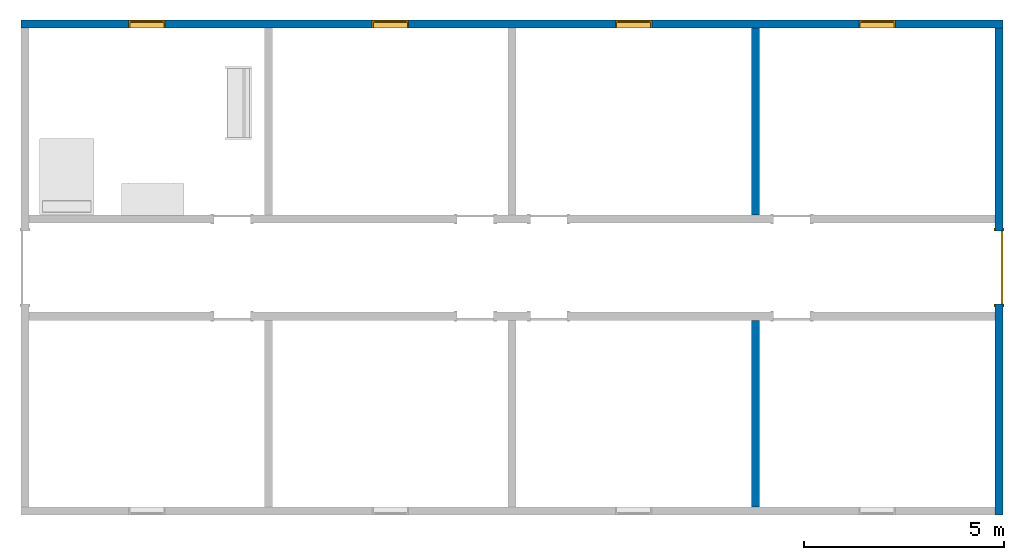
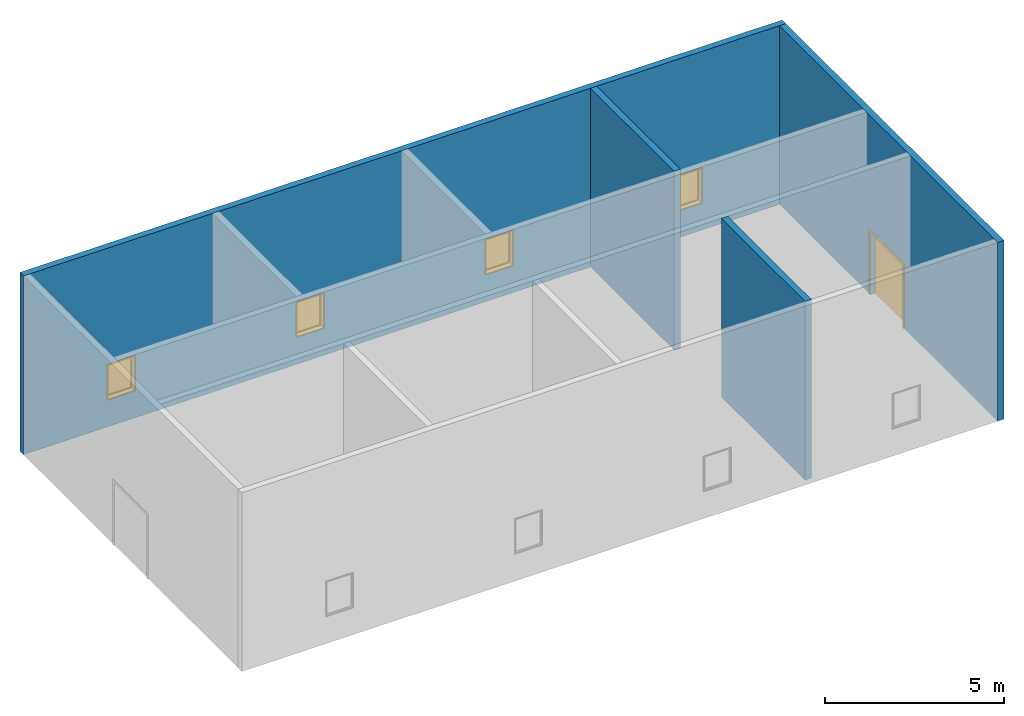
# One storey, part 2 of 4: 4 walls, 4 windows, 1 door, 5 openings.
"""IFC2X3 building model written with IfcOpenShell, lengths in feet."""

import ifcopenshell
import ifcopenshell.guid

model = None  # the IFC model being written
_history = None  # IfcOwnerHistory: only IFC2X3 demands one
_inside = {}  # id of a spatial element -> (the spatial element, [elements in it])
_under = {}  # id of a project, library or spatial element -> (it, [spatial elements below it])
_declared = {}  # id of a project -> (the project, [libraries it declares])
_typed = {}  # id of a type object -> (the type object, [elements of that type])
_made_of = {}  # id of a material, layer set ... -> (it, [elements and type objects made of it])


def new_model(schema):
    """Start an empty IFC model of exactly this schema.

    Asked for "IFC4X3", IfcOpenShell would pick the latest addendum, in which some entities
    have other attributes; the version numbers below select the first issue.
    IFC2X3 requires an IfcOwnerHistory on every rooted entity: one is made here for all.
    """
    global model, _history
    if schema == "IFC4X3":
        model = ifcopenshell.file(schema_version=(4, 3, 0, 0))
    else:
        model = ifcopenshell.file(schema=schema)
    _inside.clear()
    _under.clear()
    _declared.clear()
    _typed.clear()
    _made_of.clear()
    _history = None
    if model.schema == "IFC2X3":
        org = make("IfcOrganization", Name="unknown")
        user = make(
            "IfcPersonAndOrganization",
            ThePerson=make("IfcPerson", FamilyName="unknown"),
            TheOrganization=org,
        )
        app = make(
            "IfcApplication",
            ApplicationDeveloper=org,
            Version="unknown",
            ApplicationFullName="unknown",
            ApplicationIdentifier="unknown",
        )
        _history = make(
            "IfcOwnerHistory",
            OwningUser=user,
            OwningApplication=app,
            ChangeAction="ADDED",
            CreationDate=0,
        )
    return model


def make(cls, **values):
    """One entity of the class cls with the attributes given. An attribute that is None is left unset."""
    return model.create_entity(
        cls, **{name: value for name, value in values.items() if value is not None}
    )


def entity(cls, *values):
    """Any entity or typed value of the class cls, its attributes in the order of the schema. None: left unset."""
    e = model.create_entity(cls)
    for i, value in enumerate(values):
        if value is not None:
            e[i] = value
    return e


def rooted(cls, **values):
    """An entity with a GlobalId (a new one), such as an element, a storey or a relation."""
    return make(cls, GlobalId=ifcopenshell.guid.new(), OwnerHistory=_history, **values)


def si_unit(unit_type, name, prefix=None):
    """IfcSIUnit, for example si_unit("LENGTHUNIT", "METRE", prefix="MILLI")."""
    return make("IfcSIUnit", UnitType=unit_type, Prefix=prefix, Name=name)


def converted_unit(unit_type, name, factor, base, dimensions=None, offset=None):
    """IfcConversionBasedUnit, such as the inch: factor (a typed value) times the base unit."""
    return make(
        "IfcConversionBasedUnit"
        if offset is None
        else "IfcConversionBasedUnitWithOffset",
        ConversionOffset=offset,
        Dimensions=None
        if dimensions is None
        else entity("IfcDimensionalExponents", *dimensions),
        UnitType=unit_type,
        Name=name,
        ConversionFactor=make(
            "IfcMeasureWithUnit", ValueComponent=factor, UnitComponent=base
        ),
    )


def derived_unit(unit_type, elements):
    """IfcDerivedUnit: a product of units, each with its exponent."""
    return make(
        "IfcDerivedUnit",
        Elements=[
            make("IfcDerivedUnitElement", Unit=unit, Exponent=power)
            for unit, power in elements
        ],
        UnitType=unit_type,
    )


def assignment(units):
    """IfcUnitAssignment: the units of a project."""
    return None if units is None else make("IfcUnitAssignment", Units=units)


def point(xyz):
    """IfcCartesianPoint."""
    return None if xyz is None else make("IfcCartesianPoint", Coordinates=xyz)


def direction(xyz):
    """IfcDirection."""
    return None if xyz is None else make("IfcDirection", DirectionRatios=xyz)


def frame(location, z_axis=None, x_axis=None):
    """IfcAxis2Placement3D, a coordinate frame: its origin and axes. An axis left out is left unset."""
    return make(
        "IfcAxis2Placement3D",
        Location=point(location),
        Axis=direction(z_axis),
        RefDirection=direction(x_axis),
    )


def frame_2d(location, x_axis=None):
    """IfcAxis2Placement2D, a coordinate frame in the plane: its origin and x axis."""
    return make(
        "IfcAxis2Placement2D", Location=point(location), RefDirection=direction(x_axis)
    )


def origin():
    """The frame at (0, 0, 0) with its axes left unset."""
    return frame((0.0, 0.0, 0.0))


def place(relative_to, where):
    """IfcLocalPlacement: puts the frame where relative to a parent placement (None: the world)."""
    return make(
        "IfcLocalPlacement", PlacementRelTo=relative_to, RelativePlacement=where
    )


def context(
    kind, dimensions, precision=None, world=None, true_north=None, identifier=None
):
    """IfcGeometricRepresentationContext, for example the 3D "Model" context."""
    return make(
        "IfcGeometricRepresentationContext",
        ContextIdentifier=identifier,
        ContextType=kind,
        CoordinateSpaceDimension=dimensions,
        Precision=precision,
        WorldCoordinateSystem=world,
        TrueNorth=true_north,
    )


def subcontext(parent, identifier, kind, view, scale=None):
    """IfcGeometricRepresentationSubContext, for example "Body" below "Model"."""
    return make(
        "IfcGeometricRepresentationSubContext",
        ContextIdentifier=identifier,
        ContextType=kind,
        ParentContext=parent,
        TargetScale=scale,
        TargetView=view,
    )


def project(units=None, contexts=None):
    """IfcProject with its units and contexts."""
    return rooted(
        "IfcProject",
        Name="project",
        RepresentationContexts=contexts,
        UnitsInContext=assignment(units),
    )


def spatial(cls, under=None, at=None, **own):
    """A site, building, storey or space (cls), placed at a placement, below another one or the project."""
    s = rooted(cls, ObjectPlacement=at, **own)
    if under is not None:
        _under.setdefault(under.id(), (under, []))[1].append(s)
    return s


def polyline(points):
    """IfcPolyline through the points."""
    return make("IfcPolyline", Points=[point(p) for p in points])


def profile(cls, at=None, kind="AREA", **sizes):
    """A parametric profile (cls). Its sizes go by their IFC names, for example OverallWidth=200.0."""
    return make(cls, ProfileType=kind, Position=at, **sizes)


def rectangle(**sizes):
    """IfcRectangleProfileDef."""
    return profile("IfcRectangleProfileDef", **sizes)


def outline(outer, holes=None, kind="AREA"):
    """IfcArbitraryClosedProfileDef: a profile drawn as a closed curve; with holes, ...WithVoids."""
    if holes is None:
        return make("IfcArbitraryClosedProfileDef", ProfileType=kind, OuterCurve=outer)
    return make(
        "IfcArbitraryProfileDefWithVoids",
        ProfileType=kind,
        OuterCurve=outer,
        InnerCurves=holes,
    )


def extrude(swept, where, along, depth):
    """IfcExtrudedAreaSolid: the profile swept, set in the frame where, extruded along a direction by depth."""
    return make(
        "IfcExtrudedAreaSolid",
        SweptArea=swept,
        Position=where,
        ExtrudedDirection=direction(along),
        Depth=depth,
    )


def shape(context_of_items, identifier, shape_type, items):
    """IfcShapeRepresentation: the items that make up one representation, for example the "Body"."""
    return make(
        "IfcShapeRepresentation",
        ContextOfItems=context_of_items,
        RepresentationIdentifier=identifier,
        RepresentationType=shape_type,
        Items=items,
    )


def source(mapping_origin, context_of_items, identifier, shape_type, items):
    """IfcRepresentationMap: a shape defined once, which mapped items show again and again."""
    return make(
        "IfcRepresentationMap",
        MappingOrigin=mapping_origin,
        MappedRepresentation=shape(context_of_items, identifier, shape_type, items),
    )


def transform(
    local_origin,
    x_axis=None,
    y_axis=None,
    z_axis=None,
    scale=None,
    scale2=None,
    scale3=None,
    uniform=True,
):
    """IfcCartesianTransformationOperator3D, or its non-uniform kind. x_axis, y_axis, z_axis: its Axis1, 2, 3."""
    if uniform:
        return make(
            "IfcCartesianTransformationOperator3D",
            Axis1=direction(x_axis),
            Axis2=direction(y_axis),
            LocalOrigin=point(local_origin),
            Scale=scale,
            Axis3=direction(z_axis),
        )
    return make(
        "IfcCartesianTransformationOperator3DnonUniform",
        Axis1=direction(x_axis),
        Axis2=direction(y_axis),
        LocalOrigin=point(local_origin),
        Scale=scale,
        Axis3=direction(z_axis),
        Scale2=scale2,
        Scale3=scale3,
    )


def mapped(mapping_source, mapping_target):
    """IfcMappedItem: shows the shape of a source again, moved by a transform."""
    return make(
        "IfcMappedItem", MappingSource=mapping_source, MappingTarget=mapping_target
    )


def material(Name=None, Category=None):
    """IfcMaterial."""
    return make("IfcMaterial", Name=Name, Category=Category)


def material_list(materials):
    """IfcMaterialList."""
    return make("IfcMaterialList", Materials=materials)


def layer(
    of_material, thickness, ventilated=None, Name=None, Category=None, Priority=None
):
    """IfcMaterialLayer: one layer of a wall or slab, of a material (None: an air gap)."""
    return make(
        "IfcMaterialLayer",
        Material=of_material,
        LayerThickness=thickness,
        IsVentilated=ventilated,
        Name=Name,
        Category=Category,
        Priority=Priority,
    )


def layer_set(layers, Name=None):
    """IfcMaterialLayerSet."""
    return make("IfcMaterialLayerSet", MaterialLayers=layers, LayerSetName=Name)


def layer_usage(for_layer_set, set_direction, sense, offset, extent=None):
    """IfcMaterialLayerSetUsage: how a layer set lies in its element."""
    return make(
        "IfcMaterialLayerSetUsage",
        ForLayerSet=for_layer_set,
        LayerSetDirection=set_direction,
        DirectionSense=sense,
        OffsetFromReferenceLine=offset,
        ReferenceExtent=extent,
    )


def made_of(thing, what):
    """Note that an element or type object is made of a material, layer set ...; save() writes the relation."""
    if what is not None:
        _made_of.setdefault(what.id(), (what, []))[1].append(thing)
    return thing


def type_object(cls, material=None, **own):
    """A type object (cls), such as IfcWallType, which elements share."""
    return made_of(rooted(cls, **own), material)


def type_shapes(of_type, sources):
    """Give a type object the sources (RepresentationMaps) that its elements show as mapped items."""
    of_type.RepresentationMaps = sources


def element(
    cls,
    number,
    at=None,
    inside=None,
    cuts=None,
    type_object=None,
    material=None,
    context=None,
    identifier="Body",
    shape_type=None,
    held_by="IfcProductDefinitionShape",
    body=None,
    shapes=None,
    **own,
):
    """One element of the class cls, such as IfcWall. Its Tag is "e" and its number.

    at: its placement. inside: the storey or other place that contains it. cuts: it is an
    opening in that element (IfcRelVoidsElement). A single representation is given by context,
    identifier, shape_type and body (its items); several are given by shapes. held_by: the class
    of the entity that holds the representations. save() writes the other relations.
    """
    e = rooted(cls, Tag="e%d" % number, ObjectPlacement=at, **own)
    if body is not None:
        shapes = [shape(context, identifier, shape_type, body)]
    if shapes is not None:
        e.Representation = make(held_by, Representations=shapes)
    if inside is not None:
        _inside.setdefault(inside.id(), (inside, []))[1].append(e)
    if cuts is not None:
        rooted(
            "IfcRelVoidsElement", RelatingBuildingElement=cuts, RelatedOpeningElement=e
        )
    if type_object is not None:
        _typed.setdefault(type_object.id(), (type_object, []))[1].append(e)
    return made_of(e, material)


def fill(opening, filler):
    """IfcRelFillsElement: the door or window that sits in an opening."""
    return rooted(
        "IfcRelFillsElement",
        RelatingOpeningElement=opening,
        RelatedBuildingElement=filler,
    )


def aggregate(whole, parts):
    """IfcRelAggregates: a whole, such as a stair, and the parts it consists of."""
    return rooted("IfcRelAggregates", RelatingObject=whole, RelatedObjects=parts)


def save(model, path):
    """Write the relations noted so far, then the file.

    IfcRelAggregates (storeys below a building ...), IfcRelContainedInSpatialStructure (elements
    in a storey), IfcRelDefinesByType, IfcRelAssociatesMaterial and IfcRelDeclares: one each for
    every whole, place, type object, material and project.
    """
    for whole, parts in _under.values():
        aggregate(whole, parts)
    for where, things in _inside.values():
        rooted(
            "IfcRelContainedInSpatialStructure",
            RelatedElements=things,
            RelatingStructure=where,
        )
    for kind, things in _typed.values():
        rooted("IfcRelDefinesByType", RelatedObjects=things, RelatingType=kind)
    for what, things in _made_of.values():
        rooted("IfcRelAssociatesMaterial", RelatedObjects=things, RelatingMaterial=what)
    for by, libraries in _declared.values():
        rooted("IfcRelDeclares", RelatingContext=by, RelatedDefinitions=libraries)
    model.write(path)


model = new_model("IFC2X3")

# Units and contexts
model_context = context("Model", 3, precision=0.0001, world=origin(), true_north=direction((6.123031769111886e-17, 1.0)))
body_context = subcontext(model_context, "Body", "Model", "MODEL_VIEW")
ifc_project = project(units=[converted_unit("LENGTHUNIT", "FOOT", entity("IfcRatioMeasure", 0.3048), si_unit("LENGTHUNIT", "METRE"), dimensions=[1, 0, 0, 0, 0, 0, 0]), converted_unit("AREAUNIT", "SQUARE FOOT", entity("IfcRatioMeasure", 0.09290304), si_unit("AREAUNIT", "SQUARE_METRE"), dimensions=[2, 0, 0, 0, 0, 0, 0]), converted_unit("VOLUMEUNIT", "CUBIC FOOT", entity("IfcRatioMeasure", 0.028316846592000004), si_unit("VOLUMEUNIT", "CUBIC_METRE"), dimensions=[3, 0, 0, 0, 0, 0, 0]), converted_unit("PLANEANGLEUNIT", "DEGREE", entity("IfcRatioMeasure", 0.017453292519943278), si_unit("PLANEANGLEUNIT", "RADIAN"), dimensions=[0, 0, 0, 0, 0, 0, 0]), si_unit("MASSUNIT", "GRAM", prefix="KILO"), derived_unit("MASSDENSITYUNIT", [(si_unit("MASSUNIT", "GRAM", prefix="KILO"), 1), (si_unit("LENGTHUNIT", "METRE"), -3)]), derived_unit("MOMENTOFINERTIAUNIT", [(si_unit("LENGTHUNIT", "METRE"), 4)]), si_unit("TIMEUNIT", "SECOND"), si_unit("FREQUENCYUNIT", "HERTZ"), si_unit("THERMODYNAMICTEMPERATUREUNIT", "DEGREE_CELSIUS"), derived_unit("THERMALTRANSMITTANCEUNIT", [(si_unit("MASSUNIT", "GRAM", prefix="KILO"), 1), (si_unit("THERMODYNAMICTEMPERATUREUNIT", "KELVIN"), -1), (si_unit("TIMEUNIT", "SECOND"), -3)]), derived_unit("VOLUMETRICFLOWRATEUNIT", [(si_unit("LENGTHUNIT", "METRE"), 3), (si_unit("TIMEUNIT", "SECOND"), -1)]), derived_unit("MASSFLOWRATEUNIT", [(si_unit("MASSUNIT", "GRAM", prefix="KILO"), 1), (si_unit("TIMEUNIT", "SECOND"), -1)]), derived_unit("ROTATIONALFREQUENCYUNIT", [(si_unit("TIMEUNIT", "SECOND"), -1)]), si_unit("ELECTRICCURRENTUNIT", "AMPERE"), si_unit("ELECTRICVOLTAGEUNIT", "VOLT"), si_unit("POWERUNIT", "WATT"), si_unit("FORCEUNIT", "NEWTON"), si_unit("ILLUMINANCEUNIT", "LUX"), si_unit("LUMINOUSFLUXUNIT", "LUMEN"), si_unit("LUMINOUSINTENSITYUNIT", "CANDELA"), derived_unit("USERDEFINED", [(si_unit("MASSUNIT", "GRAM", prefix="KILO"), -1), (si_unit("LENGTHUNIT", "METRE"), -2), (si_unit("TIMEUNIT", "SECOND"), 3), (si_unit("LUMINOUSFLUXUNIT", "LUMEN"), 1)]), derived_unit("SOUNDPOWERUNIT", [(si_unit("MASSUNIT", "GRAM", prefix="KILO"), 1), (si_unit("LENGTHUNIT", "METRE"), 2), (si_unit("TIMEUNIT", "SECOND"), -3)]), derived_unit("SOUNDPRESSUREUNIT", [(si_unit("MASSUNIT", "GRAM", prefix="KILO"), 1), (si_unit("LENGTHUNIT", "METRE"), -1), (si_unit("TIMEUNIT", "SECOND"), -2)]), derived_unit("LINEARVELOCITYUNIT", [(si_unit("LENGTHUNIT", "METRE"), 1), (si_unit("TIMEUNIT", "SECOND"), -1)]), si_unit("PRESSUREUNIT", "PASCAL"), derived_unit("USERDEFINED", [(si_unit("LENGTHUNIT", "METRE"), -2), (si_unit("MASSUNIT", "GRAM", prefix="KILO"), 1), (si_unit("TIMEUNIT", "SECOND"), -2)]), derived_unit("LINEARFORCEUNIT", [(si_unit("MASSUNIT", "GRAM", prefix="KILO"), 1), (si_unit("LENGTHUNIT", "METRE"), 1), (si_unit("TIMEUNIT", "SECOND"), -2), (si_unit("LENGTHUNIT", "METRE"), -1)]), derived_unit("PLANARFORCEUNIT", [(si_unit("MASSUNIT", "GRAM", prefix="KILO"), 1), (si_unit("LENGTHUNIT", "METRE"), 1), (si_unit("TIMEUNIT", "SECOND"), -2), (si_unit("LENGTHUNIT", "METRE"), -2)])], contexts=[model_context])

# Site, building, storey
site_placement = place(None, origin())
site = spatial("IfcSite", under=ifc_project, at=site_placement, CompositionType="ELEMENT")
building_placement = place(site_placement, origin())
building = spatial("IfcBuilding", under=site, at=building_placement, CompositionType="ELEMENT")
storey_placement = place(building_placement, origin())
storey = spatial("IfcBuildingStorey", under=building, at=storey_placement, Name="Level 1", CompositionType="ELEMENT", Elevation=0.0)

# Wall, openings, windows
ifc_material_1 = material(Name="Default Wall")
ifc_layer = layer(ifc_material_1, 0.6666666666666666)
ifc_layer_set = layer_set([ifc_layer])
ifc_layer_usage_1 = layer_usage(ifc_layer_set, "AXIS2", "NEGATIVE", 0.3333333333333333)
wall_type = type_object("IfcWallType", PredefinedType="STANDARD", material=ifc_layer_set)
wall_1_placement = place(storey_placement, frame((-39.42285318603628, 29.258738116057074, 0.0)))
wall_1 = element("IfcWallStandardCase", 1, at=wall_1_placement, inside=storey, type_object=wall_type, material=ifc_layer_usage_1, context=body_context, shape_type="SweptSolid", body=[
    extrude(rectangle(XDim=80.66666666666661, YDim=0.6666666666666679, at=frame_2d((40.33333333333331, -5.828670879282072e-16), x_axis=(-1.0, 0.0))), origin(), (0.0, 0.0, 1.0), 20.0),
])
opening_1_placement = place(wall_1_placement, frame((68.83333333333326, -0.33333333333355597, 3.0)))
opening_1 = element("IfcOpeningElement", 2, at=opening_1_placement, cuts=wall_1, ObjectType="Opening", context=body_context, shape_type="SweptSolid", body=[
    extrude(rectangle(XDim=4.0, YDim=2.9999999999999987, at=frame_2d((2.0, 1.5000000000000007), x_axis=(-1.0, 0.0))), frame((0.0, 0.0, 0.0), z_axis=(0.0, 1.0, 0.0), x_axis=(0.0, 0.0, 1.0)), (0.0, 0.0, 1.0), 0.6666666666666666),
])
opening_2_placement = place(wall_1_placement, frame((48.83333333333326, -0.333333333333492, 3.0)))
opening_2 = element("IfcOpeningElement", 3, at=opening_2_placement, cuts=wall_1, ObjectType="Opening", context=body_context, shape_type="SweptSolid", body=[
    extrude(rectangle(XDim=4.0, YDim=2.9999999999999987, at=frame_2d((2.0, 1.4999999999999993), x_axis=(-1.0, 0.0))), frame((0.0, 0.0, 0.0), z_axis=(0.0, 1.0, 0.0), x_axis=(0.0, 0.0, 1.0)), (0.0, 0.0, 1.0), 0.6666666666666666),
])
opening_3_placement = place(wall_1_placement, frame((28.83333333333328, -0.3333333333334245, 3.0)))
opening_3 = element("IfcOpeningElement", 4, at=opening_3_placement, cuts=wall_1, ObjectType="Opening", context=body_context, shape_type="SweptSolid", body=[
    extrude(rectangle(XDim=4.0, YDim=2.9999999999999987, at=frame_2d((2.0, 1.5000000000000007), x_axis=(-1.0, 0.0))), frame((0.0, 0.0, 0.0), z_axis=(0.0, 1.0, 0.0), x_axis=(0.0, 0.0, 1.0)), (0.0, 0.0, 1.0), 0.6666666666666666),
])
opening_4_placement = place(wall_1_placement, frame((8.833333333333332, -0.33333333333336057, 3.0)))
opening_4 = element("IfcOpeningElement", 5, at=opening_4_placement, cuts=wall_1, ObjectType="Opening", context=body_context, shape_type="SweptSolid", body=[
    extrude(rectangle(XDim=4.0, YDim=2.9999999999999987, at=frame_2d((2.0, 1.5000000000000007), x_axis=(-1.0, 0.0))), frame((0.0, 0.0, 0.0), z_axis=(0.0, 1.0, 0.0), x_axis=(0.0, 0.0, 1.0)), (0.0, 0.0, 1.0), 0.6666666666666666),
])
ifc_material_2 = material(Name="Glass")
ifc_material_3 = material(Name="Sash")
ifc_material_list_1 = material_list([ifc_material_2, ifc_material_3])
ifc_material_list_2 = material_list([ifc_material_2, ifc_material_3, ifc_material_3, ifc_material_3])
window_style_1 = type_object("IfcWindowStyle", ConstructionType="NOTDEFINED", OperationType="NOTDEFINED", ParameterTakesPrecedence=False, Sizeable=False, material=ifc_material_list_2)
shared_shape_1 = source(origin(), body_context, "Body", "SweptSolid", [
    extrude(rectangle(XDim=2.5833333333333313, YDim=0.04166666666666666, at=frame_2d((0.0, -1.3877787807814457e-17), x_axis=(1.0, 0.0))), frame((1.7500000000000173, 0.53125, 0.2083333333333215)), (0.0, 0.0, 1.0), 3.5833333333333393),
    extrude(outline(polyline([(-1.4374999999999971, -1.9375000000000053), (1.4374999999999971, -1.9375000000000053), (1.4374999999999971, 1.9375000000000053), (-1.4374999999999971, 1.9375000000000053), (-1.4374999999999971, -1.9375000000000053)]), holes=[polyline([(-1.291666666666665, -1.7916666666666696), (-1.291666666666665, 1.7916666666666696), (1.2916666666666663, 1.7916666666666696), (1.2916666666666663, -1.7916666666666696), (-1.291666666666665, -1.7916666666666696)])]), frame((1.750000000000018, 0.6041666666666666, 2.0), z_axis=(0.0, -1.0, 0.0), x_axis=(-1.0, 0.0, 0.0)), (0.0, 0.0, 1.0), 0.14583333333333331),
    extrude(outline(polyline([(-1.499999999999997, -2.0), (1.499999999999997, -2.0), (1.499999999999997, 2.0), (-1.499999999999997, 2.0), (-1.499999999999997, -2.0)]), holes=[polyline([(-1.3958333333333353, -1.8958333333333277), (-1.3958333333333353, 1.8958333333333508), (1.3958333333333293, 1.8958333333333508), (1.3958333333333293, -1.8958333333333277), (-1.3958333333333353, -1.8958333333333277)])]), frame((1.7500000000000149, 0.4583333333333333, 2.0), z_axis=(0.0, -1.0, 0.0), x_axis=(-1.0, 0.0, 0.0)), (0.0, 0.0, 1.0), 0.4583333333333333),
    extrude(outline(polyline([(-2.0, -1.5000000000000002), (2.0, -1.5000000000000002), (2.0, 1.5000000000000002), (-2.0, 1.5000000000000002), (-2.0, -1.5000000000000002)]), holes=[polyline([(-1.9374999999999973, -1.4374999999999953), (-1.9374999999999973, 1.4375000000000016), (1.9375000000000115, 1.4375000000000016), (1.9375000000000115, -1.4374999999999953), (-1.9374999999999973, -1.4374999999999953)])]), frame((1.7500000000000149, 0.6666666666666666, 2.0), z_axis=(0.0, -1.0, 0.0), x_axis=(0.0, 0.0, -1.0)), (0.0, 0.0, 1.0), 0.20833333333333331),
])
type_shapes(window_style_1, [shared_shape_1])
window_1_placement = place(opening_1_placement, frame((-0.25000000000001776, 0.0, 0.0)))
window_1 = element("IfcWindow", 6, at=window_1_placement, inside=storey, type_object=window_style_1, material=ifc_material_list_1, OverallHeight=4.0, OverallWidth=3.0, context=body_context, shape_type="MappedRepresentation", body=[
    mapped(shared_shape_1, transform((0.0, 0.0, 0.0), scale=1.0)),
])
fill(opening_1, window_1)
ifc_material_list_3 = material_list([ifc_material_2, ifc_material_3])
window_2_placement = place(opening_3_placement, frame((-0.25000000000001776, 0.0, 0.0)))
window_2 = element("IfcWindow", 7, at=window_2_placement, inside=storey, type_object=window_style_1, material=ifc_material_list_3, OverallHeight=4.0, OverallWidth=3.0, context=body_context, shape_type="MappedRepresentation", body=[
    mapped(shared_shape_1, transform((0.0, 0.0, 0.0), scale=1.0)),
])
fill(opening_3, window_2)
ifc_material_list_4 = material_list([ifc_material_2, ifc_material_3])
window_3_placement = place(opening_4_placement, frame((-0.2500000000000213, 0.0, 0.0)))
window_3 = element("IfcWindow", 8, at=window_3_placement, inside=storey, type_object=window_style_1, material=ifc_material_list_4, OverallHeight=4.0, OverallWidth=3.0, context=body_context, shape_type="MappedRepresentation", body=[
    mapped(shared_shape_1, transform((0.0, 0.0, 0.0), scale=1.0)),
])
fill(opening_4, window_3)
ifc_material_list_5 = material_list([ifc_material_2, ifc_material_3, ifc_material_3, ifc_material_3])
ifc_material_list_6 = material_list([ifc_material_2, ifc_material_3, ifc_material_3, ifc_material_3])
window_style_2 = type_object("IfcWindowStyle", ConstructionType="NOTDEFINED", OperationType="NOTDEFINED", ParameterTakesPrecedence=False, Sizeable=False, material=ifc_material_list_6)
shared_shape_2 = source(origin(), body_context, "Body", "SweptSolid", [
    extrude(rectangle(XDim=0.04166666666666666, YDim=2.5833333333333313, at=frame_2d((1.3877787807814457e-17, 0.0), x_axis=(1.0, 0.0))), frame((1.5000000000000013, 0.53125, 0.2083333333333215), z_axis=(0.0, 0.0, 1.0), x_axis=(0.0, 1.0, 0.0)), (0.0, 0.0, 1.0), 3.5833333333333393),
    extrude(outline(polyline([(-1.4374999999999971, -1.9375000000000053), (1.4374999999999971, -1.9375000000000053), (1.4374999999999971, 1.9375000000000053), (-1.4374999999999971, 1.9375000000000053), (-1.4374999999999971, -1.9375000000000053)]), holes=[polyline([(-1.291666666666665, -1.7916666666666696), (-1.291666666666665, 1.7916666666666696), (1.2916666666666663, 1.7916666666666696), (1.2916666666666663, -1.7916666666666696), (-1.291666666666665, -1.7916666666666696)])]), frame((1.5000000000000007, 0.4583333333333333, 2.0), z_axis=(0.0, 1.0, 0.0), x_axis=(1.0, 0.0, 0.0)), (0.0, 0.0, 1.0), 0.14583333333333331),
    extrude(outline(polyline([(-1.499999999999997, -2.0), (1.499999999999997, -2.0), (1.499999999999997, 2.0), (-1.499999999999997, 2.0), (-1.499999999999997, -2.0)]), holes=[polyline([(-1.3958333333333353, -1.8958333333333277), (-1.3958333333333353, 1.8958333333333508), (1.3958333333333293, 1.8958333333333508), (1.3958333333333293, -1.8958333333333277), (-1.3958333333333353, -1.8958333333333277)])]), frame((1.5000000000000038, 0.0, 2.0), z_axis=(0.0, 1.0, 0.0), x_axis=(1.0, 0.0, 0.0)), (0.0, 0.0, 1.0), 0.4583333333333333),
    extrude(outline(polyline([(-2.0, -1.5000000000000002), (2.0, -1.5000000000000002), (2.0, 1.5000000000000002), (-2.0, 1.5000000000000002), (-2.0, -1.5000000000000002)]), holes=[polyline([(-1.9374999999999973, -1.4374999999999953), (-1.9374999999999973, 1.4375000000000016), (1.9375000000000115, 1.4375000000000016), (1.9375000000000115, -1.4374999999999953), (-1.9374999999999973, -1.4374999999999953)])]), frame((1.5000000000000038, 0.4583333333333333, 2.0), z_axis=(0.0, 1.0, 0.0), x_axis=(0.0, 0.0, -1.0)), (0.0, 0.0, 1.0), 0.20833333333333331),
])
type_shapes(window_style_2, [shared_shape_2])
window_4_placement = place(opening_2_placement, origin())
window_4 = element("IfcWindow", 9, at=window_4_placement, inside=storey, type_object=window_style_2, material=ifc_material_list_5, OverallHeight=4.0, OverallWidth=2.9999999999999982, context=body_context, shape_type="MappedRepresentation", body=[
    mapped(shared_shape_2, transform((0.0, 0.0, 0.0), scale=1.0)),
])
fill(opening_2, window_4)

# Wall, opening, door
ifc_layer_usage_2 = layer_usage(ifc_layer_set, "AXIS2", "NEGATIVE", 0.3333333333333333)
wall_2_placement = place(storey_placement, frame((40.910480147297, 28.925404782723483, 0.0), z_axis=(0.0, 0.0, 1.0), x_axis=(0.0, -1.0, 0.0)))
wall_2 = element("IfcWallStandardCase", 10, at=wall_2_placement, inside=storey, type_object=wall_type, material=ifc_layer_usage_2, context=body_context, shape_type="SweptSolid", body=[
    extrude(rectangle(XDim=40.0, YDim=0.6666666666666643, at=frame_2d((20.0, 3.552713678800501e-15), x_axis=(1.0, 0.0))), origin(), (0.0, 0.0, 1.0), 20.0),
])
opening_5_placement = place(wall_2_placement, frame((16.666666666666647, -0.33333333333332343, 0.0)))
opening_5 = element("IfcOpeningElement", 11, at=opening_5_placement, cuts=wall_2, ObjectType="Opening", context=body_context, shape_type="SweptSolid", body=[
    extrude(rectangle(XDim=6.999999999999998, YDim=5.999999999999998, at=frame_2d((3.499999999999999, 2.999999999999999), x_axis=(1.0, 0.0))), frame((0.0, 0.0, 0.0), z_axis=(0.0, 1.0, 0.0), x_axis=(0.0, 0.0, 1.0)), (0.0, 0.0, 1.0), 0.6666666666666666),
])
ifc_material_4 = material(Name="Paint - Sienna")
ifc_material_5 = material(Name="Wood - Birch - Solid Stained Light Low Gloss")
ifc_material_list_7 = material_list([ifc_material_4, ifc_material_4, ifc_material_5, ifc_material_5])
ifc_material_list_8 = material_list([ifc_material_4, ifc_material_4, ifc_material_5, ifc_material_5])
door_style = type_object("IfcDoorStyle", ConstructionType="NOTDEFINED", OperationType="DOUBLE_DOOR_SINGLE_SWING_OPPOSITE_LEFT", ParameterTakesPrecedence=False, Sizeable=False, material=ifc_material_list_8)
shared_shape_3 = source(origin(), body_context, "Body", "SweptSolid", [
    extrude(outline(polyline([(-3.437499999999999, 3.0), (3.562499999999999, 3.0), (3.562499999999999, 3.249999999999999), (-3.687499999999999, 3.249999999999999), (-3.687499999999999, -3.249999999999999), (3.562499999999999, -3.249999999999999), (3.562499999999999, -3.0), (-3.437499999999999, -3.0), (-3.437499999999999, 3.0)])), frame((3.0, -0.08333333333334297, 3.562499999999999), z_axis=(0.0, 1.0, 0.0), x_axis=(0.0, 0.0, -1.0)), (0.0, 0.0, 1.0), 0.08333333333333331),
    extrude(outline(polyline([(-3.437499999999999, 3.0), (3.562499999999999, 3.0), (3.562499999999999, 3.25), (-3.687499999999999, 3.25), (-3.687499999999999, -3.25), (3.562499999999999, -3.25), (3.562499999999999, -3.0), (-3.437499999999999, -3.0), (-3.437499999999999, 3.0)])), frame((3.0, 0.666666666666657, 3.562499999999999), z_axis=(0.0, 1.0, 0.0), x_axis=(0.0, 0.0, -1.0)), (0.0, 0.0, 1.0), 0.08333333333333331),
    extrude(rectangle(XDim=0.1666666666666505, YDim=3.0000000000000013, at=frame_2d((-1.3877787807814457e-17, 0.0), x_axis=(1.0, 0.0))), frame((4.5, 0.5833333333333155, 0.0), z_axis=(0.0, 0.0, 1.0), x_axis=(0.0, -1.0, 0.0)), (0.0, 0.0, 1.0), 6.999999999999998),
    extrude(rectangle(XDim=0.16666666666666669, YDim=2.9999999999999947, at=frame_2d((-1.3877787807814457e-17, -2.220446049250313e-16), x_axis=(1.0, 0.0))), frame((1.5000000000000018, 0.5833333333333284, 0.0), z_axis=(0.0, 0.0, 1.0), x_axis=(0.0, -1.0, 0.0)), (0.0, 0.0, 1.0), 7.0),
])
type_shapes(door_style, [shared_shape_3])
door_placement = place(opening_5_placement, origin())
door = element("IfcDoor", 12, at=door_placement, inside=storey, type_object=door_style, material=ifc_material_list_7, OverallHeight=6.999999999999998, OverallWidth=5.999999999999998, context=body_context, shape_type="MappedRepresentation", body=[
    mapped(shared_shape_3, transform((0.0, 0.0, 0.0), scale=1.0)),
])
fill(opening_5, door)

# Walls
ifc_layer_usage_3 = layer_usage(ifc_layer_set, "AXIS2", "NEGATIVE", 0.3333333333333333)
wall_3_placement = place(storey_placement, frame((20.91048014729696, 28.925404782723547, 0.0), z_axis=(0.0, 0.0, 1.0), x_axis=(0.0, -1.0, 0.0)))
element("IfcWallStandardCase", 13, at=wall_3_placement, inside=storey, type_object=wall_type, material=ifc_layer_usage_3, context=body_context, shape_type="SweptSolid", body=[
    extrude(rectangle(XDim=15.333333333333334, YDim=0.6666666666666643, at=frame_2d((7.666666666666667, -5.273559366969494e-16), x_axis=(-1.0, 0.0))), origin(), (0.0, 0.0, 1.0), 20.0),
])
ifc_layer_usage_4 = layer_usage(ifc_layer_set, "AXIS2", "NEGATIVE", 0.3333333333333333)
wall_4_placement = place(storey_placement, frame((20.910480147296923, 4.925404782723547, 0.0), z_axis=(0.0, 0.0, 1.0), x_axis=(0.0, -1.0, 0.0)))
element("IfcWallStandardCase", 14, at=wall_4_placement, inside=storey, type_object=wall_type, material=ifc_layer_usage_4, context=body_context, shape_type="SweptSolid", body=[
    extrude(rectangle(XDim=15.333333333333336, YDim=0.6666666666666643, at=frame_2d((7.666666666666668, -5.273559366969494e-16), x_axis=(-1.0, 0.0))), origin(), (0.0, 0.0, 1.0), 20.0),
])

save(model, "model.ifc")
